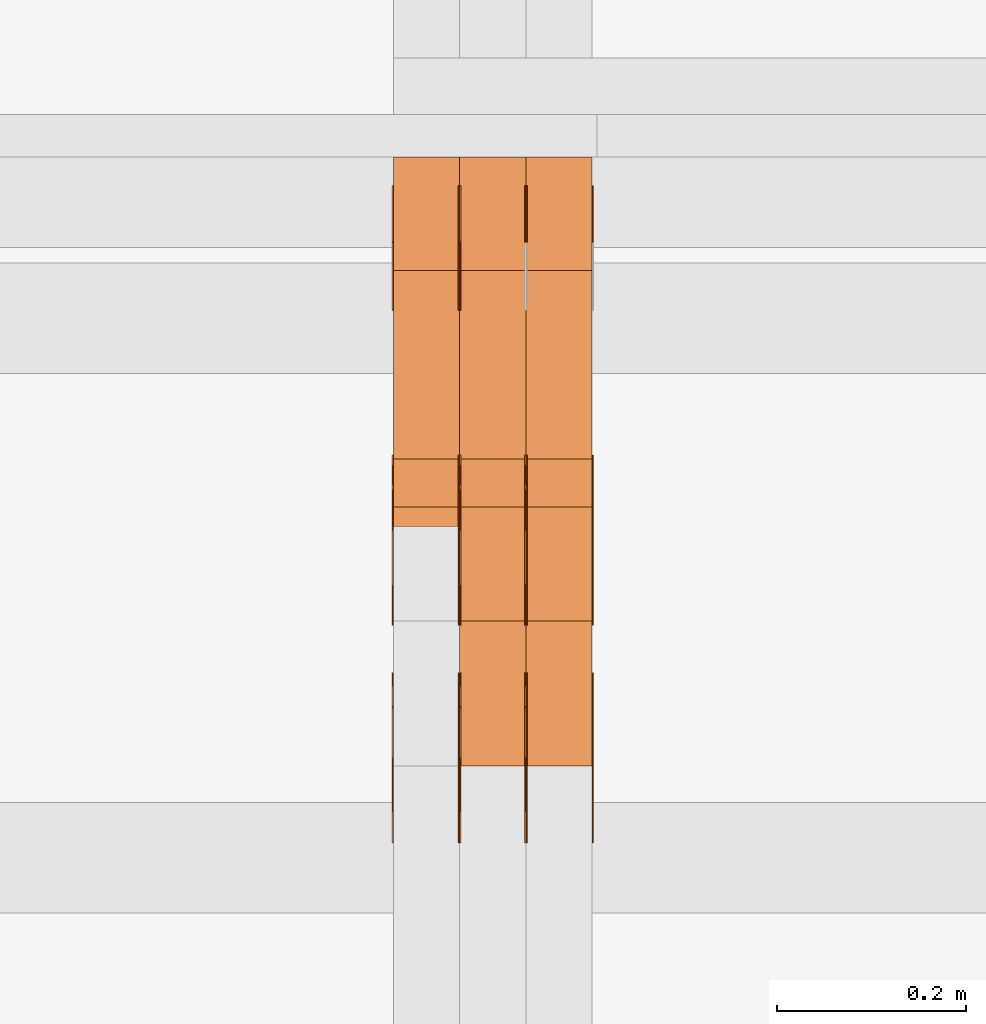
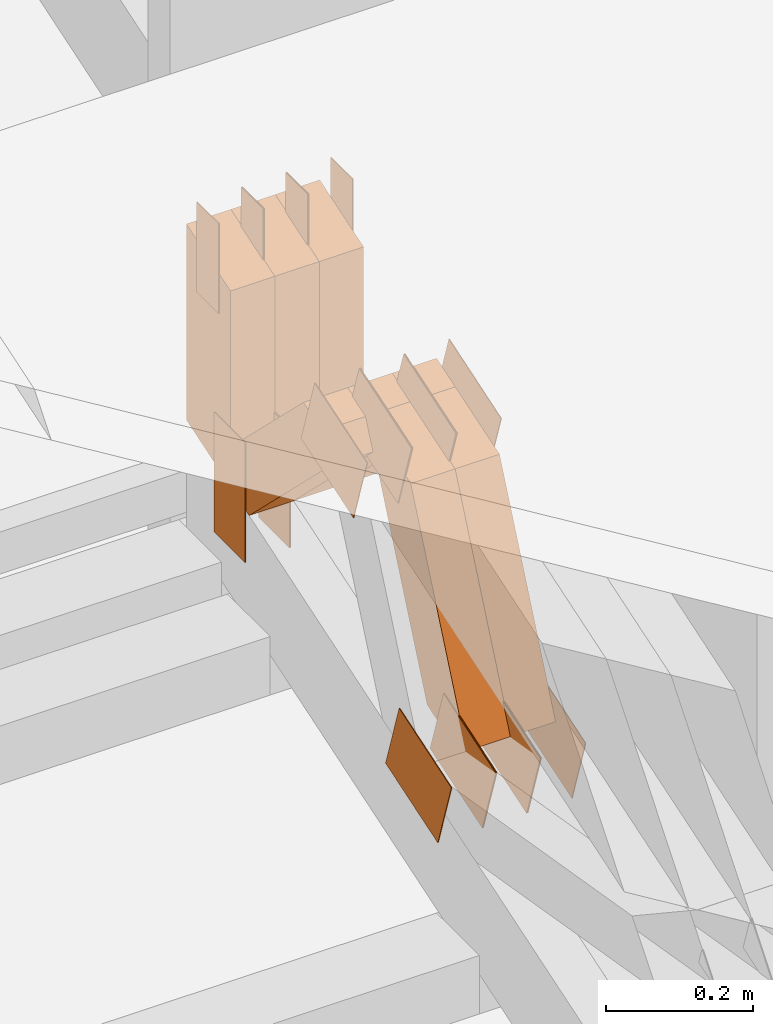
# One storey, part 156 of 385: 29 proxies.
"""IFC2X3 building model written with IfcOpenShell, lengths in millimetres."""

from ifc_helpers import new_model, entity, si_unit, converted_unit, derived_unit, direction, frame, frame_2d, origin, origin_2d_with_axis, place, context, subcontext, project, spatial, polyline, rectangle, outline, extrude, source, transform, mapped, material, type_object, type_shapes, element, save


model = new_model("IFC2X3")

# Units and contexts
model_context = context("Model", 3, precision=0.01, world=origin(), true_north=direction((6.12303176911189e-17, 1.0)))
body_context = subcontext(model_context, "Body", "Model", "MODEL_VIEW")
ifc_project = project(units=[si_unit("LENGTHUNIT", "METRE", prefix="MILLI"), si_unit("AREAUNIT", "SQUARE_METRE"), si_unit("VOLUMEUNIT", "CUBIC_METRE"), converted_unit("PLANEANGLEUNIT", "DEGREE", entity("IfcRatioMeasure", 0.0174532925199433), si_unit("PLANEANGLEUNIT", "RADIAN"), dimensions=[0, 0, 0, 0, 0, 0, 0]), si_unit("MASSUNIT", "GRAM", prefix="KILO"), derived_unit("MASSDENSITYUNIT", [(si_unit("MASSUNIT", "GRAM", prefix="KILO"), 1), (si_unit("LENGTHUNIT", "METRE"), -3)]), si_unit("TIMEUNIT", "SECOND"), si_unit("FREQUENCYUNIT", "HERTZ"), si_unit("THERMODYNAMICTEMPERATUREUNIT", "DEGREE_CELSIUS"), derived_unit("THERMALTRANSMITTANCEUNIT", [(si_unit("MASSUNIT", "GRAM", prefix="KILO"), 1), (si_unit("THERMODYNAMICTEMPERATUREUNIT", "KELVIN"), -1), (si_unit("TIMEUNIT", "SECOND"), -3)]), derived_unit("VOLUMETRICFLOWRATEUNIT", [(si_unit("LENGTHUNIT", "METRE"), 3), (si_unit("TIMEUNIT", "SECOND"), -1)]), si_unit("ELECTRICCURRENTUNIT", "AMPERE"), si_unit("ELECTRICVOLTAGEUNIT", "VOLT"), si_unit("POWERUNIT", "WATT"), si_unit("FORCEUNIT", "NEWTON", prefix="KILO"), si_unit("ILLUMINANCEUNIT", "LUX"), si_unit("LUMINOUSFLUXUNIT", "LUMEN"), si_unit("LUMINOUSINTENSITYUNIT", "CANDELA"), derived_unit("USERDEFINED", [(si_unit("MASSUNIT", "GRAM", prefix="KILO"), -1), (si_unit("LENGTHUNIT", "METRE"), -2), (si_unit("TIMEUNIT", "SECOND"), 3), (si_unit("LUMINOUSFLUXUNIT", "LUMEN"), 1)]), derived_unit("LINEARVELOCITYUNIT", [(si_unit("LENGTHUNIT", "METRE"), 1), (si_unit("TIMEUNIT", "SECOND"), -1)]), si_unit("PRESSUREUNIT", "PASCAL"), derived_unit("USERDEFINED", [(si_unit("LENGTHUNIT", "METRE"), -2), (si_unit("MASSUNIT", "GRAM", prefix="KILO"), 1), (si_unit("TIMEUNIT", "SECOND"), -2)])], contexts=[model_context])

# Site, building, storey
site_placement = place(None, origin())
site = spatial("IfcSite", under=ifc_project, at=site_placement, CompositionType="ELEMENT")
building_placement = place(site_placement, origin())
building = spatial("IfcBuilding", under=site, at=building_placement, CompositionType="ELEMENT")
storey_placement = place(building_placement, origin())
storey = spatial("IfcBuildingStorey", under=building, at=storey_placement, Name="Default", CompositionType="ELEMENT", Elevation=0.0)

# Proxies
ifc_material_1 = material(Name="IfcSurfaceStyle #312265")
building_element_proxy_type_1 = type_object("IfcBuildingElementProxyType", PredefinedType="NOTDEFINED", material=ifc_material_1)
shared_shape_1 = source(origin(), body_context, "Body", "SweptSolid", [
    extrude(rectangle(XDim=200.0, YDim=84.0, at=frame_2d((0.0, -7.105427357601e-15), x_axis=(1.0, 0.0))), frame((100.0, 42.0, 0.0), z_axis=(0.0, 0.0, 1.0), x_axis=(-1.0, 0.0, 0.0)), (0.0, 0.0, 1.0), 1.29999999999998),
])
type_shapes(building_element_proxy_type_1, [shared_shape_1])
proxy_1_placement = place(building_placement, frame((24245.0, 13702.0, 3651.4150390625), z_axis=(-1.0, 0.0, 0.0), x_axis=(0.0, 0.0, -1.0)))
element("IfcBuildingElementProxy", 1, at=proxy_1_placement, inside=storey, type_object=building_element_proxy_type_1, material=ifc_material_1, context=body_context, shape_type="MappedRepresentation", body=[
    mapped(shared_shape_1, transform((0.0, 0.0, 0.0), scale=1.0)),
])
ifc_material_2 = material(Name="IfcSurfaceStyle #312208")
building_element_proxy_type_2 = type_object("IfcBuildingElementProxyType", PredefinedType="NOTDEFINED", material=ifc_material_2)
shared_shape_2 = source(origin(), body_context, "Body", "SweptSolid", [
    extrude(rectangle(XDim=200.0, YDim=84.0, at=frame_2d((0.0, -7.105427357601e-15), x_axis=(1.0, 0.0))), frame((100.0, 42.0, 0.0), z_axis=(0.0, 0.0, 1.0), x_axis=(-1.0, 0.0, 0.0)), (0.0, 0.0, 1.0), 1.29999999999998),
])
type_shapes(building_element_proxy_type_2, [shared_shape_2])
proxy_2_placement = place(building_placement, frame((24246.3, 13702.0, 3651.4150390625), z_axis=(-1.0, 0.0, 0.0), x_axis=(0.0, 0.0, -1.0)))
element("IfcBuildingElementProxy", 2, at=proxy_2_placement, inside=storey, type_object=building_element_proxy_type_2, material=ifc_material_2, context=body_context, shape_type="MappedRepresentation", body=[
    mapped(shared_shape_2, transform((0.0, 0.0, 0.0), scale=1.0)),
])
ifc_material_3 = material(Name="IfcSurfaceStyle #312151")
building_element_proxy_type_3 = type_object("IfcBuildingElementProxyType", PredefinedType="NOTDEFINED", material=ifc_material_3)
shared_shape_3 = source(origin(), body_context, "Body", "SweptSolid", [
    extrude(rectangle(XDim=200.0, YDim=84.0, at=frame_2d((0.0, -7.105427357601e-15), x_axis=(1.0, 0.0))), frame((100.0, 42.0, 0.0), z_axis=(0.0, 0.0, 1.0), x_axis=(-1.0, 0.0, 0.0)), (0.0, 0.0, 1.0), 1.29999999999999),
])
type_shapes(building_element_proxy_type_3, [shared_shape_3])
proxy_3_placement = place(building_placement, frame((24175.0, 13702.0, 3651.4150390625), z_axis=(-1.0, 0.0, 0.0), x_axis=(0.0, 0.0, -1.0)))
element("IfcBuildingElementProxy", 3, at=proxy_3_placement, inside=storey, type_object=building_element_proxy_type_3, material=ifc_material_3, context=body_context, shape_type="MappedRepresentation", body=[
    mapped(shared_shape_3, transform((0.0, 0.0, 0.0), scale=1.0)),
])
ifc_material_4 = material(Name="IfcSurfaceStyle #312094")
building_element_proxy_type_4 = type_object("IfcBuildingElementProxyType", PredefinedType="NOTDEFINED", material=ifc_material_4)
shared_shape_4 = source(origin(), body_context, "Body", "SweptSolid", [
    extrude(outline(polyline([(-75.0003398116828, -59.9998507501386), (75.0003249421766, -59.9998507501386), (75.0003398116837, 59.9998507501387), (-75.0003249421775, 59.9998507501387), (-75.0003398116828, -59.9998507501386)])), frame((75.0003398116837, 60.0000773549637, 0.0), z_axis=(0.0, 0.0, 1.0), x_axis=(-1.0, 0.0, 0.0)), (0.0, 0.0, 1.0), 1.3),
])
type_shapes(building_element_proxy_type_4, [shared_shape_4])
proxy_4_placement = place(building_placement, frame((24386.3, 13054.73046875, 3417.8388671875), z_axis=(-1.0, 0.0, 0.0), x_axis=(0.0, 0.951056516295124, 0.309016994375039)))
element("IfcBuildingElementProxy", 4, at=proxy_4_placement, inside=storey, type_object=building_element_proxy_type_4, material=ifc_material_4, context=body_context, shape_type="MappedRepresentation", body=[
    mapped(shared_shape_4, transform((0.0, 0.0, 0.0), scale=1.0)),
])
ifc_material_5 = material(Name="IfcSurfaceStyle #312037")
building_element_proxy_type_5 = type_object("IfcBuildingElementProxyType", PredefinedType="NOTDEFINED", material=ifc_material_5)
shared_shape_5 = source(origin(), body_context, "Body", "SweptSolid", [
    extrude(outline(polyline([(-75.0003398116828, -59.9998507501386), (75.0003249421766, -59.9998507501386), (75.0003398116837, 59.9998507501387), (-75.0003249421775, 59.9998507501387), (-75.0003398116828, -59.9998507501386)])), frame((75.0003398116837, 60.0000773549637, 0.0), z_axis=(0.0, 0.0, 1.0), x_axis=(-1.0, 0.0, 0.0)), (0.0, 0.0, 1.0), 1.3),
])
type_shapes(building_element_proxy_type_5, [shared_shape_5])
proxy_5_placement = place(building_placement, frame((24315.0, 13054.73046875, 3417.8388671875), z_axis=(-1.0, 0.0, 0.0), x_axis=(0.0, 0.951056516295124, 0.309016994375039)))
element("IfcBuildingElementProxy", 5, at=proxy_5_placement, inside=storey, type_object=building_element_proxy_type_5, material=ifc_material_5, context=body_context, shape_type="MappedRepresentation", body=[
    mapped(shared_shape_5, transform((0.0, 0.0, 0.0), scale=1.0)),
])
ifc_material_6 = material(Name="IfcSurfaceStyle #311980")
building_element_proxy_type_6 = type_object("IfcBuildingElementProxyType", PredefinedType="NOTDEFINED", material=ifc_material_6)
shared_shape_6 = source(origin(), body_context, "Body", "SweptSolid", [
    extrude(outline(polyline([(-75.0003398116828, -59.9998507501386), (75.0003249421766, -59.9998507501386), (75.0003398116837, 59.9998507501387), (-75.0003249421775, 59.9998507501387), (-75.0003398116828, -59.9998507501386)])), frame((75.0003398116837, 60.0000773549637, 0.0), z_axis=(0.0, 0.0, 1.0), x_axis=(-1.0, 0.0, 0.0)), (0.0, 0.0, 1.0), 1.3),
])
type_shapes(building_element_proxy_type_6, [shared_shape_6])
proxy_6_placement = place(building_placement, frame((24316.3, 13054.73046875, 3417.8388671875), z_axis=(-1.0, 0.0, 0.0), x_axis=(0.0, 0.951056516295124, 0.309016994375039)))
element("IfcBuildingElementProxy", 6, at=proxy_6_placement, inside=storey, type_object=building_element_proxy_type_6, material=ifc_material_6, context=body_context, shape_type="MappedRepresentation", body=[
    mapped(shared_shape_6, transform((0.0, 0.0, 0.0), scale=1.0)),
])
ifc_material_7 = material(Name="IfcSurfaceStyle #311923")
building_element_proxy_type_7 = type_object("IfcBuildingElementProxyType", PredefinedType="NOTDEFINED", material=ifc_material_7)
shared_shape_7 = source(origin(), body_context, "Body", "SweptSolid", [
    extrude(outline(polyline([(-75.0003398116828, -59.9998507501386), (75.0003249421766, -59.9998507501386), (75.0003398116837, 59.9998507501387), (-75.0003249421775, 59.9998507501387), (-75.0003398116828, -59.9998507501386)])), frame((75.0003398116837, 60.0000773549637, 0.0), z_axis=(0.0, 0.0, 1.0), x_axis=(-1.0, 0.0, 0.0)), (0.0, 0.0, 1.0), 1.29999999999999),
])
type_shapes(building_element_proxy_type_7, [shared_shape_7])
proxy_7_placement = place(building_placement, frame((24245.0, 13054.73046875, 3417.8388671875), z_axis=(-1.0, 0.0, 0.0), x_axis=(0.0, 0.951056516295124, 0.309016994375039)))
element("IfcBuildingElementProxy", 7, at=proxy_7_placement, inside=storey, type_object=building_element_proxy_type_7, material=ifc_material_7, context=body_context, shape_type="MappedRepresentation", body=[
    mapped(shared_shape_7, transform((0.0, 0.0, 0.0), scale=1.0)),
])
ifc_material_8 = material(Name="IfcSurfaceStyle #311866")
building_element_proxy_type_8 = type_object("IfcBuildingElementProxyType", PredefinedType="NOTDEFINED", material=ifc_material_8)
shared_shape_8 = source(origin(), body_context, "Body", "SweptSolid", [
    extrude(outline(polyline([(-75.0003398116828, -59.9998507501386), (75.0003249421766, -59.9998507501386), (75.0003398116837, 59.9998507501387), (-75.0003249421775, 59.9998507501387), (-75.0003398116828, -59.9998507501386)])), frame((75.0003398116837, 60.0000773549637, 0.0), z_axis=(0.0, 0.0, 1.0), x_axis=(-1.0, 0.0, 0.0)), (0.0, 0.0, 1.0), 1.29999999999999),
])
type_shapes(building_element_proxy_type_8, [shared_shape_8])
proxy_8_placement = place(building_placement, frame((24246.3, 13054.73046875, 3417.8388671875), z_axis=(-1.0, 0.0, 0.0), x_axis=(0.0, 0.951056516295124, 0.309016994375039)))
element("IfcBuildingElementProxy", 8, at=proxy_8_placement, inside=storey, type_object=building_element_proxy_type_8, material=ifc_material_8, context=body_context, shape_type="MappedRepresentation", body=[
    mapped(shared_shape_8, transform((0.0, 0.0, 0.0), scale=1.0)),
])
ifc_material_9 = material(Name="IfcSurfaceStyle #311809")
building_element_proxy_type_9 = type_object("IfcBuildingElementProxyType", PredefinedType="NOTDEFINED", material=ifc_material_9)
shared_shape_9 = source(origin(), body_context, "Body", "SweptSolid", [
    extrude(outline(polyline([(-75.0003398116828, -59.9998507501386), (75.0003249421766, -59.9998507501386), (75.0003398116837, 59.9998507501387), (-75.0003249421775, 59.9998507501387), (-75.0003398116828, -59.9998507501386)])), frame((75.0003398116837, 60.0000773549637, 0.0), z_axis=(0.0, 0.0, 1.0), x_axis=(-1.0, 0.0, 0.0)), (0.0, 0.0, 1.0), 1.29999999999999),
])
type_shapes(building_element_proxy_type_9, [shared_shape_9])
proxy_9_placement = place(building_placement, frame((24175.0, 13054.73046875, 3417.8388671875), z_axis=(-1.0, 0.0, 0.0), x_axis=(0.0, 0.951056516295124, 0.309016994375039)))
element("IfcBuildingElementProxy", 9, at=proxy_9_placement, inside=storey, type_object=building_element_proxy_type_9, material=ifc_material_9, context=body_context, shape_type="MappedRepresentation", body=[
    mapped(shared_shape_9, transform((0.0, 0.0, 0.0), scale=1.0)),
])
ifc_material_10 = material(Name="IfcSurfaceStyle #304228")
building_element_proxy_type_10 = type_object("IfcBuildingElementProxyType", PredefinedType="NOTDEFINED", material=ifc_material_10)
shared_shape_10 = source(origin(), body_context, "Body", "SweptSolid", [
    extrude(outline(polyline([(-74.999875428623, -60.0000016373506), (74.9998605591059, -60.0000016373506), (74.9998754286239, 60.0000016373506), (-74.9998605591068, 60.0000016373506), (-74.999875428623, -60.0000016373506)])), frame((75.0002691827262, 60.0000190504561, 0.0), z_axis=(0.0, 0.0, 1.0), x_axis=(-1.0, 0.0, 0.0)), (0.0, 0.0, 1.0), 1.3),
])
type_shapes(building_element_proxy_type_10, [shared_shape_10])
proxy_10_placement = place(building_placement, frame((24386.3, 13285.0865109705, 3819.37496637467), z_axis=(-1.0, 0.0, 0.0), x_axis=(0.0, 0.951056516295154, 0.309016994374948)))
element("IfcBuildingElementProxy", 10, at=proxy_10_placement, inside=storey, type_object=building_element_proxy_type_10, material=ifc_material_10, context=body_context, shape_type="MappedRepresentation", body=[
    mapped(shared_shape_10, transform((0.0, 0.0, 0.0), scale=1.0)),
])
ifc_material_11 = material(Name="IfcSurfaceStyle #304171")
building_element_proxy_type_11 = type_object("IfcBuildingElementProxyType", PredefinedType="NOTDEFINED", material=ifc_material_11)
shared_shape_11 = source(origin(), body_context, "Body", "SweptSolid", [
    extrude(outline(polyline([(-74.999875428623, -60.0000016373506), (74.9998605591059, -60.0000016373506), (74.9998754286239, 60.0000016373506), (-74.9998605591068, 60.0000016373506), (-74.999875428623, -60.0000016373506)])), frame((75.0002691827262, 60.0000190504561, 0.0), z_axis=(0.0, 0.0, 1.0), x_axis=(-1.0, 0.0, 0.0)), (0.0, 0.0, 1.0), 1.3),
])
type_shapes(building_element_proxy_type_11, [shared_shape_11])
proxy_11_placement = place(building_placement, frame((24315.0, 13285.0865109705, 3819.37496637467), z_axis=(-1.0, 0.0, 0.0), x_axis=(0.0, 0.951056516295154, 0.309016994374948)))
element("IfcBuildingElementProxy", 11, at=proxy_11_placement, inside=storey, type_object=building_element_proxy_type_11, material=ifc_material_11, context=body_context, shape_type="MappedRepresentation", body=[
    mapped(shared_shape_11, transform((0.0, 0.0, 0.0), scale=1.0)),
])
ifc_material_12 = material(Name="IfcSurfaceStyle #304114")
building_element_proxy_type_12 = type_object("IfcBuildingElementProxyType", PredefinedType="NOTDEFINED", material=ifc_material_12)
shared_shape_12 = source(origin(), body_context, "Body", "SweptSolid", [
    extrude(outline(polyline([(-74.999875428623, -60.0000016373506), (74.9998605591059, -60.0000016373506), (74.9998754286239, 60.0000016373506), (-74.9998605591068, 60.0000016373506), (-74.999875428623, -60.0000016373506)])), frame((75.0002691827262, 60.0000190504561, 0.0), z_axis=(0.0, 0.0, 1.0), x_axis=(-1.0, 0.0, 0.0)), (0.0, 0.0, 1.0), 1.3),
])
type_shapes(building_element_proxy_type_12, [shared_shape_12])
proxy_12_placement = place(building_placement, frame((24316.3, 13285.0865109705, 3819.37496637467), z_axis=(-1.0, 0.0, 0.0), x_axis=(0.0, 0.951056516295154, 0.309016994374948)))
element("IfcBuildingElementProxy", 12, at=proxy_12_placement, inside=storey, type_object=building_element_proxy_type_12, material=ifc_material_12, context=body_context, shape_type="MappedRepresentation", body=[
    mapped(shared_shape_12, transform((0.0, 0.0, 0.0), scale=1.0)),
])
ifc_material_13 = material(Name="IfcSurfaceStyle #304057")
building_element_proxy_type_13 = type_object("IfcBuildingElementProxyType", PredefinedType="NOTDEFINED", material=ifc_material_13)
shared_shape_13 = source(origin(), body_context, "Body", "SweptSolid", [
    extrude(outline(polyline([(-74.999875428623, -60.0000016373506), (74.9998605591059, -60.0000016373506), (74.9998754286239, 60.0000016373506), (-74.9998605591068, 60.0000016373506), (-74.999875428623, -60.0000016373506)])), frame((75.0002691827262, 60.0000190504561, 0.0), z_axis=(0.0, 0.0, 1.0), x_axis=(-1.0, 0.0, 0.0)), (0.0, 0.0, 1.0), 1.29999999999999),
])
type_shapes(building_element_proxy_type_13, [shared_shape_13])
proxy_13_placement = place(building_placement, frame((24245.0, 13285.0865109705, 3819.37496637467), z_axis=(-1.0, 0.0, 0.0), x_axis=(0.0, 0.951056516295154, 0.309016994374948)))
element("IfcBuildingElementProxy", 13, at=proxy_13_placement, inside=storey, type_object=building_element_proxy_type_13, material=ifc_material_13, context=body_context, shape_type="MappedRepresentation", body=[
    mapped(shared_shape_13, transform((0.0, 0.0, 0.0), scale=1.0)),
])
ifc_material_14 = material(Name="IfcSurfaceStyle #304000")
building_element_proxy_type_14 = type_object("IfcBuildingElementProxyType", PredefinedType="NOTDEFINED", material=ifc_material_14)
shared_shape_14 = source(origin(), body_context, "Body", "SweptSolid", [
    extrude(outline(polyline([(-74.999875428623, -60.0000016373506), (74.9998605591059, -60.0000016373506), (74.9998754286239, 60.0000016373506), (-74.9998605591068, 60.0000016373506), (-74.999875428623, -60.0000016373506)])), frame((75.0002691827262, 60.0000190504561, 0.0), z_axis=(0.0, 0.0, 1.0), x_axis=(-1.0, 0.0, 0.0)), (0.0, 0.0, 1.0), 1.29999999999999),
])
type_shapes(building_element_proxy_type_14, [shared_shape_14])
proxy_14_placement = place(building_placement, frame((24246.3, 13285.0865109705, 3819.37496637467), z_axis=(-1.0, 0.0, 0.0), x_axis=(0.0, 0.951056516295154, 0.309016994374948)))
element("IfcBuildingElementProxy", 14, at=proxy_14_placement, inside=storey, type_object=building_element_proxy_type_14, material=ifc_material_14, context=body_context, shape_type="MappedRepresentation", body=[
    mapped(shared_shape_14, transform((0.0, 0.0, 0.0), scale=1.0)),
])
ifc_material_15 = material(Name="IfcSurfaceStyle #303943")
building_element_proxy_type_15 = type_object("IfcBuildingElementProxyType", PredefinedType="NOTDEFINED", material=ifc_material_15)
shared_shape_15 = source(origin(), body_context, "Body", "SweptSolid", [
    extrude(outline(polyline([(-74.999875428623, -60.0000016373506), (74.9998605591059, -60.0000016373506), (74.9998754286239, 60.0000016373506), (-74.9998605591068, 60.0000016373506), (-74.999875428623, -60.0000016373506)])), frame((75.0002691827262, 60.0000190504561, 0.0), z_axis=(0.0, 0.0, 1.0), x_axis=(-1.0, 0.0, 0.0)), (0.0, 0.0, 1.0), 1.29999999999999),
])
type_shapes(building_element_proxy_type_15, [shared_shape_15])
proxy_15_placement = place(building_placement, frame((24175.0, 13285.0865109705, 3819.37496637467), z_axis=(-1.0, 0.0, 0.0), x_axis=(0.0, 0.951056516295154, 0.309016994374948)))
element("IfcBuildingElementProxy", 15, at=proxy_15_placement, inside=storey, type_object=building_element_proxy_type_15, material=ifc_material_15, context=body_context, shape_type="MappedRepresentation", body=[
    mapped(shared_shape_15, transform((0.0, 0.0, 0.0), scale=1.0)),
])
ifc_material_16 = material(Name="IfcSurfaceStyle #303544")
building_element_proxy_type_16 = type_object("IfcBuildingElementProxyType", PredefinedType="NOTDEFINED", material=ifc_material_16)
shared_shape_16 = source(origin(), body_context, "Body", "SweptSolid", [
    extrude(rectangle(XDim=150.0, YDim=60.0, at=origin_2d_with_axis()), frame((75.0000705696166, 30.0, 0.0), z_axis=(0.0, 0.0, 1.0), x_axis=(-1.0, 0.0, 0.0)), (0.0, 0.0, 1.0), 1.3),
])
type_shapes(building_element_proxy_type_16, [shared_shape_16])
proxy_16_placement = place(building_placement, frame((24386.3, 13750.0, 3972.59919166337), z_axis=(-1.0, 0.0, 0.0), x_axis=(0.0, 0.0, -1.0)))
element("IfcBuildingElementProxy", 16, at=proxy_16_placement, inside=storey, type_object=building_element_proxy_type_16, material=ifc_material_16, context=body_context, shape_type="MappedRepresentation", body=[
    mapped(shared_shape_16, transform((0.0, 0.0, 0.0), scale=1.0)),
])
ifc_material_17 = material(Name="IfcSurfaceStyle #303487")
building_element_proxy_type_17 = type_object("IfcBuildingElementProxyType", PredefinedType="NOTDEFINED", material=ifc_material_17)
shared_shape_17 = source(origin(), body_context, "Body", "SweptSolid", [
    extrude(rectangle(XDim=150.0, YDim=60.0, at=origin_2d_with_axis()), frame((75.0000705696166, 30.0, 0.0), z_axis=(0.0, 0.0, 1.0), x_axis=(-1.0, 0.0, 0.0)), (0.0, 0.0, 1.0), 1.3),
])
type_shapes(building_element_proxy_type_17, [shared_shape_17])
proxy_17_placement = place(building_placement, frame((24315.0, 13750.0, 3972.59919166337), z_axis=(-1.0, 0.0, 0.0), x_axis=(0.0, 0.0, -1.0)))
element("IfcBuildingElementProxy", 17, at=proxy_17_placement, inside=storey, type_object=building_element_proxy_type_17, material=ifc_material_17, context=body_context, shape_type="MappedRepresentation", body=[
    mapped(shared_shape_17, transform((0.0, 0.0, 0.0), scale=1.0)),
])
ifc_material_18 = material(Name="IfcSurfaceStyle #303430")
building_element_proxy_type_18 = type_object("IfcBuildingElementProxyType", PredefinedType="NOTDEFINED", material=ifc_material_18)
shared_shape_18 = source(origin(), body_context, "Body", "SweptSolid", [
    extrude(rectangle(XDim=150.0, YDim=60.0, at=origin_2d_with_axis()), frame((75.0000705696166, 30.0, 0.0), z_axis=(0.0, 0.0, 1.0), x_axis=(-1.0, 0.0, 0.0)), (0.0, 0.0, 1.0), 1.3),
])
type_shapes(building_element_proxy_type_18, [shared_shape_18])
proxy_18_placement = place(building_placement, frame((24316.3, 13750.0, 3972.59919166337), z_axis=(-1.0, 0.0, 0.0), x_axis=(0.0, 0.0, -1.0)))
element("IfcBuildingElementProxy", 18, at=proxy_18_placement, inside=storey, type_object=building_element_proxy_type_18, material=ifc_material_18, context=body_context, shape_type="MappedRepresentation", body=[
    mapped(shared_shape_18, transform((0.0, 0.0, 0.0), scale=1.0)),
])
ifc_material_19 = material(Name="IfcSurfaceStyle #303373")
building_element_proxy_type_19 = type_object("IfcBuildingElementProxyType", PredefinedType="NOTDEFINED", material=ifc_material_19)
shared_shape_19 = source(origin(), body_context, "Body", "SweptSolid", [
    extrude(rectangle(XDim=150.0, YDim=60.0, at=origin_2d_with_axis()), frame((75.0000705696166, 30.0, 0.0), z_axis=(0.0, 0.0, 1.0), x_axis=(-1.0, 0.0, 0.0)), (0.0, 0.0, 1.0), 1.29999999999999),
])
type_shapes(building_element_proxy_type_19, [shared_shape_19])
proxy_19_placement = place(building_placement, frame((24245.0, 13750.0, 3972.59919166337), z_axis=(-1.0, 0.0, 0.0), x_axis=(0.0, 0.0, -1.0)))
element("IfcBuildingElementProxy", 19, at=proxy_19_placement, inside=storey, type_object=building_element_proxy_type_19, material=ifc_material_19, context=body_context, shape_type="MappedRepresentation", body=[
    mapped(shared_shape_19, transform((0.0, 0.0, 0.0), scale=1.0)),
])
ifc_material_20 = material(Name="IfcSurfaceStyle #303316")
building_element_proxy_type_20 = type_object("IfcBuildingElementProxyType", PredefinedType="NOTDEFINED", material=ifc_material_20)
shared_shape_20 = source(origin(), body_context, "Body", "SweptSolid", [
    extrude(rectangle(XDim=150.0, YDim=60.0, at=origin_2d_with_axis()), frame((75.0000705696166, 30.0, 0.0), z_axis=(0.0, 0.0, 1.0), x_axis=(-1.0, 0.0, 0.0)), (0.0, 0.0, 1.0), 1.29999999999999),
])
type_shapes(building_element_proxy_type_20, [shared_shape_20])
proxy_20_placement = place(building_placement, frame((24246.3, 13750.0, 3972.59919166337), z_axis=(-1.0, 0.0, 0.0), x_axis=(0.0, 0.0, -1.0)))
element("IfcBuildingElementProxy", 20, at=proxy_20_placement, inside=storey, type_object=building_element_proxy_type_20, material=ifc_material_20, context=body_context, shape_type="MappedRepresentation", body=[
    mapped(shared_shape_20, transform((0.0, 0.0, 0.0), scale=1.0)),
])
ifc_material_21 = material(Name="IfcSurfaceStyle #303259")
building_element_proxy_type_21 = type_object("IfcBuildingElementProxyType", PredefinedType="NOTDEFINED", material=ifc_material_21)
shared_shape_21 = source(origin(), body_context, "Body", "SweptSolid", [
    extrude(rectangle(XDim=150.0, YDim=60.0, at=origin_2d_with_axis()), frame((75.0000705696166, 30.0, 0.0), z_axis=(0.0, 0.0, 1.0), x_axis=(-1.0, 0.0, 0.0)), (0.0, 0.0, 1.0), 1.29999999999999),
])
type_shapes(building_element_proxy_type_21, [shared_shape_21])
proxy_21_placement = place(building_placement, frame((24175.0, 13750.0, 3972.59919166337), z_axis=(-1.0, 0.0, 0.0), x_axis=(0.0, 0.0, -1.0)))
element("IfcBuildingElementProxy", 21, at=proxy_21_placement, inside=storey, type_object=building_element_proxy_type_21, material=ifc_material_21, context=body_context, shape_type="MappedRepresentation", body=[
    mapped(shared_shape_21, transform((0.0, 0.0, 0.0), scale=1.0)),
])
ifc_material_22 = material(Name="IfcSurfaceStyle #294058")
building_element_proxy_type_22 = type_object("IfcBuildingElementProxyType", Name="T1-W49 294056", PredefinedType="NOTDEFINED", material=ifc_material_22)
shared_shape_22 = source(origin(), body_context, "Body", "SweptSolid", [
    extrude(outline(polyline([(-155.175867306415, -47.4997478409253), (152.310664695054, -47.4997478409253), (170.496756790954, -6.14570120142345e-05), (145.70957993751, 47.4998092979374), (-133.37808995724, 47.4998092979373), (-179.963044159863, -6.14570120298391e-05), (-155.175867306415, -47.4997478409253)])), frame((170.496756790954, 47.5001152140455, 0.0), z_axis=(0.0, 0.0, 1.0), x_axis=(-1.0, 0.0, 0.0)), (0.0, 0.0, 1.0), 70.0),
])
type_shapes(building_element_proxy_type_22, [shared_shape_22])
proxy_22_placement = place(building_placement, frame((24385.0, 13443.048524104, 3830.71841973934), z_axis=(-1.0, 0.0, 0.0), x_axis=(0.0, 0.713950095632063, -0.700196587357413)))
element("IfcBuildingElementProxy", 22, at=proxy_22_placement, inside=storey, type_object=building_element_proxy_type_22, material=ifc_material_22, Name="T1-W49", context=body_context, shape_type="MappedRepresentation", body=[
    mapped(shared_shape_22, transform((0.0, 0.0, 0.0), scale=1.0)),
])
ifc_material_23 = material(Name="IfcSurfaceStyle #293983")
building_element_proxy_type_23 = type_object("IfcBuildingElementProxyType", Name="T1-W49 293981", PredefinedType="NOTDEFINED", material=ifc_material_23)
shared_shape_23 = source(origin(), body_context, "Body", "SweptSolid", [
    extrude(outline(polyline([(-155.175867306415, -47.4997478409253), (152.310664695054, -47.4997478409253), (170.496756790954, -6.14570120142345e-05), (145.70957993751, 47.4998092979374), (-133.37808995724, 47.4998092979373), (-179.963044159863, -6.14570120298391e-05), (-155.175867306415, -47.4997478409253)])), frame((170.496756790954, 47.5001152140455, 0.0), z_axis=(0.0, 0.0, 1.0), x_axis=(-1.0, 0.0, 0.0)), (0.0, 0.0, 1.0), 70.0),
])
type_shapes(building_element_proxy_type_23, [shared_shape_23])
proxy_23_placement = place(building_placement, frame((24315.0, 13443.048524104, 3830.71841973934), z_axis=(-1.0, 0.0, 0.0), x_axis=(0.0, 0.713950095632063, -0.700196587357413)))
element("IfcBuildingElementProxy", 23, at=proxy_23_placement, inside=storey, type_object=building_element_proxy_type_23, material=ifc_material_23, Name="T1-W49", context=body_context, shape_type="MappedRepresentation", body=[
    mapped(shared_shape_23, transform((0.0, 0.0, 0.0), scale=1.0)),
])
ifc_material_24 = material(Name="IfcSurfaceStyle #293908")
building_element_proxy_type_24 = type_object("IfcBuildingElementProxyType", Name="T1-W49 293906", PredefinedType="NOTDEFINED", material=ifc_material_24)
shared_shape_24 = source(origin(), body_context, "Body", "SweptSolid", [
    extrude(outline(polyline([(-155.175867306415, -47.4997478409253), (152.310664695054, -47.4997478409253), (170.496756790954, -6.14570120142345e-05), (145.70957993751, 47.4998092979374), (-133.37808995724, 47.4998092979373), (-179.963044159863, -6.14570120298391e-05), (-155.175867306415, -47.4997478409253)])), frame((170.496756790954, 47.5001152140455, 0.0), z_axis=(0.0, 0.0, 1.0), x_axis=(-1.0, 0.0, 0.0)), (0.0, 0.0, 1.0), 70.0),
])
type_shapes(building_element_proxy_type_24, [shared_shape_24])
proxy_24_placement = place(building_placement, frame((24245.0, 13443.048524104, 3830.71841973934), z_axis=(-1.0, 0.0, 0.0), x_axis=(0.0, 0.713950095632063, -0.700196587357413)))
element("IfcBuildingElementProxy", 24, at=proxy_24_placement, inside=storey, type_object=building_element_proxy_type_24, material=ifc_material_24, Name="T1-W49", context=body_context, shape_type="MappedRepresentation", body=[
    mapped(shared_shape_24, transform((0.0, 0.0, 0.0), scale=1.0)),
])
ifc_material_25 = material(Name="IfcSurfaceStyle #293608")
building_element_proxy_type_25 = type_object("IfcBuildingElementProxyType", Name="T1-W1 293606", PredefinedType="NOTDEFINED", material=ifc_material_25)
shared_shape_25 = source(origin(), body_context, "Body", "SweptSolid", [
    extrude(outline(polyline([(-182.839782714844, -60.0), (143.849426269531, -60.0), (182.839660644531, 60.0), (-143.849304199219, 60.0), (-182.839782714844, -60.0)])), frame((182.839674685549, 60.0, 0.0), z_axis=(0.0, 0.0, 1.0), x_axis=(-1.0, 0.0, 0.0)), (0.0, 0.0, 1.0), 70.0),
])
type_shapes(building_element_proxy_type_25, [shared_shape_25])
proxy_25_placement = place(building_placement, frame((24385.0, 13660.0, 3551.41502502148), z_axis=(-1.0, 0.0, 0.0), x_axis=(0.0, 0.0, 1.0)))
element("IfcBuildingElementProxy", 25, at=proxy_25_placement, inside=storey, type_object=building_element_proxy_type_25, material=ifc_material_25, Name="T1-W1", context=body_context, shape_type="MappedRepresentation", body=[
    mapped(shared_shape_25, transform((0.0, 0.0, 0.0), scale=1.0)),
])
ifc_material_26 = material(Name="IfcSurfaceStyle #293551")
building_element_proxy_type_26 = type_object("IfcBuildingElementProxyType", Name="T1-W1 293549", PredefinedType="NOTDEFINED", material=ifc_material_26)
shared_shape_26 = source(origin(), body_context, "Body", "SweptSolid", [
    extrude(outline(polyline([(-182.839782714844, -60.0), (143.849426269531, -60.0), (182.839660644531, 60.0), (-143.849304199219, 60.0), (-182.839782714844, -60.0)])), frame((182.839674685549, 60.0, 0.0), z_axis=(0.0, 0.0, 1.0), x_axis=(-1.0, 0.0, 0.0)), (0.0, 0.0, 1.0), 70.0),
])
type_shapes(building_element_proxy_type_26, [shared_shape_26])
proxy_26_placement = place(building_placement, frame((24315.0, 13660.0, 3551.41502502148), z_axis=(-1.0, 0.0, 0.0), x_axis=(0.0, 0.0, 1.0)))
element("IfcBuildingElementProxy", 26, at=proxy_26_placement, inside=storey, type_object=building_element_proxy_type_26, material=ifc_material_26, Name="T1-W1", context=body_context, shape_type="MappedRepresentation", body=[
    mapped(shared_shape_26, transform((0.0, 0.0, 0.0), scale=1.0)),
])
ifc_material_27 = material(Name="IfcSurfaceStyle #293494")
building_element_proxy_type_27 = type_object("IfcBuildingElementProxyType", Name="T1-W1 293492", PredefinedType="NOTDEFINED", material=ifc_material_27)
shared_shape_27 = source(origin(), body_context, "Body", "SweptSolid", [
    extrude(outline(polyline([(-182.839782714844, -60.0), (143.849426269531, -60.0), (182.839660644531, 60.0), (-143.849304199219, 60.0), (-182.839782714844, -60.0)])), frame((182.839674685549, 60.0, 0.0), z_axis=(0.0, 0.0, 1.0), x_axis=(-1.0, 0.0, 0.0)), (0.0, 0.0, 1.0), 70.0),
])
type_shapes(building_element_proxy_type_27, [shared_shape_27])
proxy_27_placement = place(building_placement, frame((24245.0, 13660.0, 3551.41502502148), z_axis=(-1.0, 0.0, 0.0), x_axis=(0.0, 0.0, 1.0)))
element("IfcBuildingElementProxy", 27, at=proxy_27_placement, inside=storey, type_object=building_element_proxy_type_27, material=ifc_material_27, Name="T1-W1", context=body_context, shape_type="MappedRepresentation", body=[
    mapped(shared_shape_27, transform((0.0, 0.0, 0.0), scale=1.0)),
])
ifc_material_28 = material(Name="IfcSurfaceStyle #293068")
building_element_proxy_type_28 = type_object("IfcBuildingElementProxyType", Name="T1-W42 293066", PredefinedType="NOTDEFINED", material=ifc_material_28)
shared_shape_28 = source(origin(), body_context, "Body", "SweptSolid", [
    extrude(outline(polyline([(-284.837590197601, -47.4997543607933), (129.95880168156, -47.4997543607933), (171.972324990451, 0.000162623346093338), (183.717007105413, 47.4996730491203), (-200.810543579822, 47.4996730491203), (-284.837590197601, -47.4997543607933)])), frame((183.717155718752, 47.4999821655365, 0.0), z_axis=(0.0, 0.0, 1.0), x_axis=(-1.0, 0.0, 0.0)), (0.0, 0.0, 1.0), 70.0),
])
type_shapes(building_element_proxy_type_28, [shared_shape_28])
proxy_28_placement = place(building_placement, frame((24385.0, 13135.8834463264, 3404.958483022), z_axis=(-1.0, 0.0, 0.0), x_axis=(0.0, 0.398630596470292, 0.917111578575769)))
element("IfcBuildingElementProxy", 28, at=proxy_28_placement, inside=storey, type_object=building_element_proxy_type_28, material=ifc_material_28, Name="T1-W42", context=body_context, shape_type="MappedRepresentation", body=[
    mapped(shared_shape_28, transform((0.0, 0.0, 0.0), scale=1.0)),
])
ifc_material_29 = material(Name="IfcSurfaceStyle #293002")
building_element_proxy_type_29 = type_object("IfcBuildingElementProxyType", Name="T1-W42 293000", PredefinedType="NOTDEFINED", material=ifc_material_29)
shared_shape_29 = source(origin(), body_context, "Body", "SweptSolid", [
    extrude(outline(polyline([(-284.837590197601, -47.4997543607933), (129.95880168156, -47.4997543607933), (171.972324990451, 0.000162623346093338), (183.717007105413, 47.4996730491203), (-200.810543579822, 47.4996730491203), (-284.837590197601, -47.4997543607933)])), frame((183.717155718752, 47.4999821655365, 0.0), z_axis=(0.0, 0.0, 1.0), x_axis=(-1.0, 0.0, 0.0)), (0.0, 0.0, 1.0), 70.0),
])
type_shapes(building_element_proxy_type_29, [shared_shape_29])
proxy_29_placement = place(building_placement, frame((24315.0, 13135.8834463264, 3404.958483022), z_axis=(-1.0, 0.0, 0.0), x_axis=(0.0, 0.398630596470292, 0.917111578575769)))
element("IfcBuildingElementProxy", 29, at=proxy_29_placement, inside=storey, type_object=building_element_proxy_type_29, material=ifc_material_29, Name="T1-W42", context=body_context, shape_type="MappedRepresentation", body=[
    mapped(shared_shape_29, transform((0.0, 0.0, 0.0), scale=1.0)),
])

save(model, "model.ifc")
